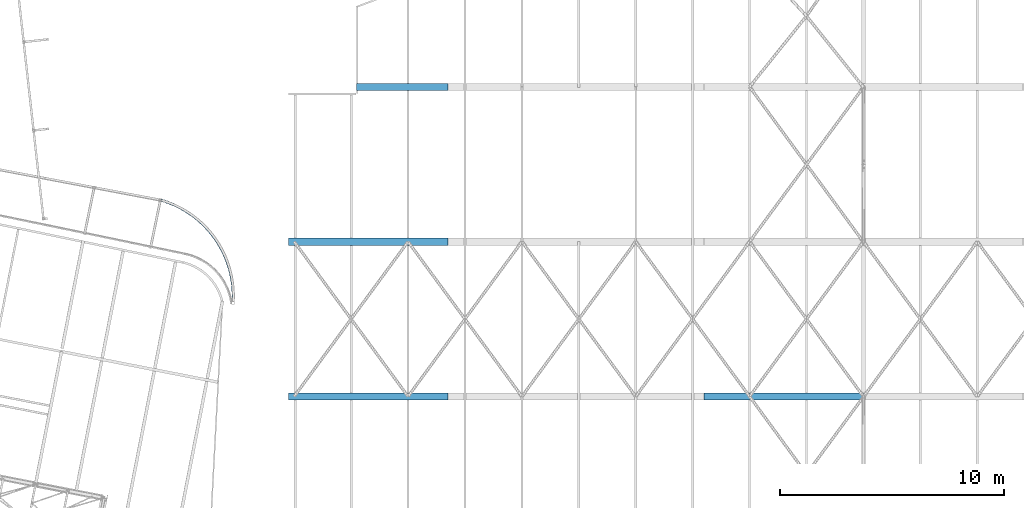
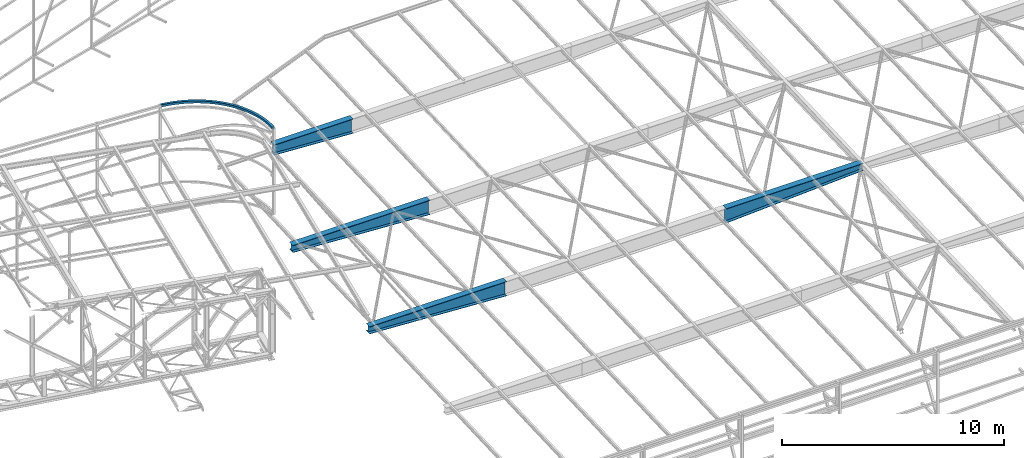
# One storey, part 214 of 215: 5 beams, 5 elements without a shape of their own.
"""IFC2X3 building model written with IfcOpenShell, lengths in millimetres."""

from ifc_helpers import new_model, si_unit, frame, origin_with_axes, place, context, subcontext, project, spatial, faceted_brep, material, type_object, element, aggregate, save


model = new_model("IFC2X3")

# Units and contexts
model_context = context("Model", 3, precision=1e-05, world=origin_with_axes())
body_context = subcontext(model_context, "Body", "Model", "MODEL_VIEW")
ifc_project = project(units=[si_unit("LENGTHUNIT", "METRE", prefix="MILLI"), si_unit("AREAUNIT", "SQUARE_METRE"), si_unit("VOLUMEUNIT", "CUBIC_METRE"), si_unit("MASSUNIT", "GRAM", prefix="KILO"), si_unit("TIMEUNIT", "SECOND"), si_unit("PLANEANGLEUNIT", "RADIAN"), si_unit("SOLIDANGLEUNIT", "STERADIAN"), si_unit("THERMODYNAMICTEMPERATUREUNIT", "DEGREE_CELSIUS"), si_unit("LUMINOUSINTENSITYUNIT", "LUMEN")], contexts=[model_context])

# Site, building, storey
site_placement = place(None, origin_with_axes())
site = spatial("IfcSite", under=ifc_project, at=site_placement, CompositionType="ELEMENT")
building_placement = place(site_placement, origin_with_axes())
building = spatial("IfcBuilding", under=site, at=building_placement, Name="Undefined", CompositionType="ELEMENT")
storey_placement = place(building_placement, origin_with_axes())
storey = spatial("IfcBuildingStorey", under=building, at=storey_placement, Name="Undefined", CompositionType="ELEMENT", Elevation=0.0)

# Assembly, beam
assembly_1_placement = place(storey_placement, origin_with_axes())
assembly_1 = element("IfcElementAssembly", 1, at=assembly_1_placement, inside=storey, Name="Steel Assembly", AssemblyPlace="NOTDEFINED", PredefinedType="RIGID_FRAME")
ifc_material_1 = material(Name="STEEL/S275JR")
beam_type_1 = type_object("IfcBeamType", PredefinedType="NOTDEFINED")
beam_1_placement = place(assembly_1_placement, frame((98183.0956430818, 57531.7367585311, 12221.3440836615), z_axis=(-0.604381100777057, -0.79669535270611, 0.0), x_axis=(0.793723850131004, -0.602126889099379, 0.0862882330142416)))
beam_1 = element("IfcBeam", 2, at=beam_1_placement, type_object=beam_type_1, material=ifc_material_1, Name="LISSE", context=body_context, shape_type="Brep", body=[
    faceted_brep([(-20.4697298194369, -60.3737340840835, -56.0000213738094), (-22.6046588798417, 59.6072730711057, -56.0000213716412), (151.538093515752, 62.5188902682512, -118.950891494111), (153.445107488122, -57.4659275622635, -118.868502462501), (22.6046588798417, -59.6072730711039, 56.0000213716557), (191.921072777841, -56.7763508783919, -5.20617546566064), (20.4697298194733, 60.3737340840853, 56.0000213737949), (190.014058805551, 63.2084669521282, -5.28856449732848), (19.1050811648311, 56.3488184784765, 52.266686615505), (21.0976816211914, -55.6334548663635, 52.266686613526), (-19.1050811648165, -56.3488184784746, -52.2666866155341), (-21.0976816211696, 55.633454866369, -52.2666866135696), (152.884192824531, 58.542382230029, -115.159400959878), (188.795093761619, 59.185987134977, -9.07456242950866), (190.574973469134, -52.7998428401697, -8.9976659999229), (154.66407253201, -53.4434477451232, -115.082504530321), (363.596040468881, -54.2669095552028, -59.4617635604081), (361.920116409747, 65.7212862085398, -59.6171854827408), (329.782553978919, -54.888332930921, -174.597604912036), (328.106629919777, 65.0998628328234, -174.753026834296), (330.853806059939, -50.8680122929381, -170.764924264367), (329.289610271429, 61.1209704198936, -170.909984725193), (362.413060117236, -50.288017142273, -63.3048056695552), (360.848864328706, 61.7009655705533, -63.449866130366), (537.3437547754, -52.083126858799, -106.676417359064), (535.901710732374, 67.9080084724374, -106.89539444253), (508.249040307725, -52.6452414099986, -223.09455003895), (506.80699626467, 67.3458939212378, -223.313527122402), (509.170795988561, -48.6267997472551, -219.22124485235), (507.824888215044, 63.3649265619024, -219.425623463583), (536.325862825019, -48.1021594994691, -110.56432101781), (534.979955051553, 63.8895668096866, -110.768699629058), (712.874957778826, -50.2286383848459, -146.771533165665), (711.669194487724, 69.7649932543027, -147.044481873294), (688.547452670282, -50.7403873334351, -264.27859936867), (687.341689379187, 69.2532443057189, -264.551548076284), (689.318177397523, -46.723541313846, -260.370795452109), (688.192798325872, 65.2705148827008, -260.625547579257), (712.023848832141, -46.2459089618278, -150.697533662678), (710.898469760483, 65.7481472347117, -150.952285789783), (889.897422380593, -48.706531514832, -179.680360002909), (888.929947213393, 71.2891490167676, -179.997606944758), (870.377627443166, -49.1769419321499, -298.081189050296), (869.410152275959, 70.8187385994497, -298.398435992145), (870.996038102145, -45.1614055671907, -294.145069646736), (870.093061279433, 66.8345629289761, -294.441166792501), (889.214513377097, -44.7223558443602, -183.637629202552), (888.311536554371, 67.2736126518084, -183.933726348274), (1068.11643880646, -47.5193402761379, -205.348110739942), (1067.38886242929, 72.4779383214154, -205.699908777839), (1053.43685090085, -47.957508054571, -324.446044002558), (1052.70927452369, 72.0397705429841, -324.797842040454), (1053.9019179518, -43.9429931753675, -320.48783949505), (1053.22284666645, 68.0544668490111, -320.816184330397), (1067.60286666371, -43.5340365821667, -209.32976844997), (1066.92379537834, 68.4634234422174, -209.658113285303), (1247.23530524402, -46.6690411233394, -223.732053302956), (1246.74883893575, 73.3293820531871, -224.108597777333), (1237.42036317838, -47.0841158333242, -343.3292716016), (1236.93389687009, 72.9143073431987, -343.705816076035), (1237.73131237027, -43.0703325704417, -339.355249140819), (1237.27727714922, 68.9281957276471, -339.706690650244), (1246.89192496488, -42.6829295077914, -227.731178728733), (1246.43788974384, 69.315598790301, -228.082620238172), (1426.95582179633, -46.1570496478162, -234.801581816195), (1426.71127543203, 73.8420627151827, -235.193026869383), (1422.02186564018, -46.5582193054815, -354.69943475422), (1421.77731927586, 73.4408930575191, -355.090879807394), (1422.1781792999, -42.5448765714591, -350.71588782467), (1421.94993602653, 69.4542949673378, -351.081236541009), (1426.78320504563, -42.1704515576366, -238.811225082536), (1426.55496177227, 69.8287199811602, -239.176573798832), (1606.97878693006, -45.9842182209959, -238.538267554963), (1606.97656763264, 74.0151267886213, -238.934742522513), (1606.93403081097, -46.3806939918286, -358.537604234312), (1606.93181151354, 73.6186510177886, -358.934079201877), (1606.93544870504, -42.3674999658069, -354.550842177283), (1606.93337736074, 69.6318887098332, -354.9208854803), (1606.97722108284, -41.9974559130351, -242.551461276526), (1606.97514973858, 70.0019327626032, -242.921504579572), (1787.00449559056, -46.1508345753482, -234.935889626329), (1787.24460705304, 73.8482861537013, -235.327515469879), (1791.8490140194, -46.5518354392771, -354.837390197325), (1792.08912548187, 73.4472852897707, -355.229016040932), (1791.69553378718, -42.5384980528488, -350.853727706432), (1791.91963781881, 69.4606812942657, -351.21924516045), (1787.17398325361, -42.1642305798396, -238.945660506826), (1787.39808728528, 69.8349487672676, -239.311177960801), (1966.73323815588, -46.6566213253518, -224.000445325553), (1967.21528063525, 73.341818569339, -224.377351079689), (1976.45896590244, -47.0713587288901, -343.604952817535), (1976.94100838181, 72.9270811658098, -343.981858571715), (1976.1508430602, -43.057586152283, -339.630699426285), (1976.60074937428, 68.9409577494334, -339.982478130187), (1967.07349716342, -42.6704979089864, -227.999825767081), (1967.5234034775, 69.3280459927355, -228.351604470954), (2145.86579939777, -47.5007364293142, -205.750140151649), (2146.58897038048, 72.4965672107028, -206.102479357185), (2160.45654491811, -47.938398950133, -324.858992032794), (2161.17971590083, 72.058904689884, -325.211331238359), (2159.99429243353, -43.9239000781054, -320.900441610283), (2160.66925201739, 68.0735833192448, -321.229291535448), (2146.3762632812, -43.5154150586732, -209.732179854531), (2147.05122286507, 68.4820683386752, -210.061029779696), (2324.10395662005, -48.6817745911612, -180.215357498848), (2325.06705215801, 71.3139392654994, -180.533324595381), (2343.5354290124, -49.1515126408613, -298.630716412445), (2344.49852455036, 70.8442012158011, -298.948683508948), (2342.91981645059, -45.1359975773157, -294.694136685241), (2343.81870561936, 66.8600020222384, -294.990905975312), (2324.78377555106, -44.6975753975948, -184.173135032514), (2325.68266471983, 67.2984242019575, -184.469904322599), (2501.15097614435, -50.1977696000558, -147.438608073542), (2502.35239285932, 69.7959035912772, -147.712454723864), (2525.39082558893, -50.7086801903806, -264.963791200964), (2526.59224230392, 69.2849930009488, -265.2376378513), (2524.62287783129, -46.6918607309944, -261.055413318361), (2525.7442000986, 65.3022342475833, -261.311003525349), (2501.99901834967, -46.2150108466885, -151.365242399494), (2503.12034061699, 65.7790841318892, -151.620832606495), (2676.71210731702, -52.0461976037404, -107.474459122124), (2678.14984506994, 67.9449874376205, -107.694510441448), (2705.71997893257, -52.6073092017559, -223.914265623185), (2707.15771668548, 67.3838758396014, -224.13431694248), (2704.80097447048, -48.5888993137778, -220.040273783787), (2706.14286303986, 63.4028733914911, -220.24565501514), (2677.72696096262, -48.0651951556247, -111.36312104945), (2679.06884953201, 63.9265775496424, -111.568502280847), (2850.4950732146, -54.2239813102988, -60.3894435861293), (2852.16673843547, 65.7642722387536, -60.5461142490094), (2884.22267424179, -54.8442388076401, -175.550479572805), (2885.8943394626, 65.1440147414123, -175.70715023567), (2883.15414304823, -50.8239551060906, -171.717000728706), (2884.714363921, 61.1650815396843, -171.863226680682), (2851.67504875622, -50.2450481085762, -64.2333671411325), (2853.23526962898, 61.743988537206, -64.3795930931519), (3022.21055723115, -56.7274951112795, -6.26194933766965), (3024.11336690374, 63.2573884835238, -6.34575953573221), (3060.6017374311, -57.4157449325539, -119.952949839091), (3062.50454710364, 62.5691386622493, -120.03676003711), (3059.38545841349, -53.3933071520205, -116.166043495643), (3061.1614141079, 58.5925842031356, -116.244266347145), (3023.5536902269, -52.7509406521622, -10.0544430276641), (3025.32964592134, 59.2349507029849, -10.1326658791659), (3191.57268473686, -59.5525711176597, 54.8179113223159), (3193.70347103213, 60.4285096713102, 54.8163200981944), (3234.56352987099, -60.3175464927917, -57.2142360611033), (3236.69431616623, 59.6635342961781, -57.2158272851811), (3233.2015279097, -56.2926779539885, -53.4798841890879), (3235.19026178525, 55.6896641157164, -53.4813693315955), (3193.07673911785, -55.5787009371998, 51.0834533686866), (3195.06547299345, 56.4036411325087, 51.0819682262227), (3358.29949900685, -62.6945060986218, 122.748451684238), (3360.65471455667, 57.2823453639066, 122.838301063806), (3405.81843724228, -63.5448125236362, 12.5612133669638), (3408.17365279212, 56.4320389388904, 12.6510627464741), (3404.31297981941, -59.5172405940502, 16.2371162901982), (3406.51118099924, 52.4611541043087, 16.3209757110744), (3359.96197079967, -58.7236212640346, 119.078538719681), (3362.16017197952, 53.254773434317, 119.162398140557), (3522.11343062684, -66.1480693115409, 197.416579919678), (3524.68915442981, 53.8241333449641, 197.606939300735), (3574.0813516904, -67.0921702219857, 89.257235182944), (3576.65707549333, 52.8800324345102, 89.4475945640152), (3572.43494511506, -63.0616267697587, 92.8688919868728), (3574.83895399777, 48.9124290429827, 93.0465607425431), (3523.93155212241, -62.1804659200061, 193.817613741121), (3526.33556100511, 49.7935898927317, 193.995282496835), (3682.74175959547, -69.9075112102564, 278.697987358057), (3685.53370354446, 50.0596309000721, 278.997758807978), (3739.07214647753, -70.9537138911637, 172.746144647477), (3741.86409042651, 49.0134282191666, 173.04591609737), (3737.28753171309, -66.9199357314556, 176.287865119506), (3739.89334606549, 45.0493969048493, 176.567651806079), (3684.71250395651, -65.9434798959446, 275.176251649391), (3687.31831830889, 46.0258527403657, 275.456038335979), (3839.91706935252, -73.9665730169581, 366.457355438091), (3842.92058537382, 45.995105231912, 366.875258873217), (3900.516142342, -75.123014772711, 262.888948115185), (3903.51965836329, 44.8386634761591, 263.306851550355), (3898.59629044305, -71.0857441058943, 266.355158473772), (3901.39957206293, 40.8784889263861, 266.745201679907), (3842.03715565288, -70.0063984671797, 363.019005308524), (3844.84043727275, 41.9578345650953, 363.409048514659), (3993.37769197823, -78.3184971419068, 460.548580988034), (3996.58777976962, 41.6373230265344, 461.09313965679), (4058.14456478848, -79.5931317491668, 359.535574433699), (4061.35465257987, 40.3626884192763, 360.080133102441), (4056.09267195452, -75.5521165899754, 362.920826607835), (4059.08875389313, 36.4066489005691, 363.429081365306), (3995.64359066496, -74.3624576232032, 457.199632725184), (3998.63967260355, 37.5963078673522, 457.707887482713), (4142.86814382229, -82.9560384336055, 560.815019460526), (4146.27945917757, 36.9935391880736, 561.494545753623), (4211.69499154824, -84.3566228997188, 462.525124784413), (4215.10630690352, 35.5929547219639, 463.204651077569), (4209.51447380253, -80.3116174967872, 465.824105483422), (4212.69836813415, 31.6413216167784, 466.45833002367), (4145.27608259169, -79.0044053284255, 557.561340514396), (4148.45997692328, 32.9485337851456, 558.195565054659), (4288.13955083698, -87.8714762406162, 667.089745716847), (4291.74641454317, 32.0714847606505, 667.912327328973), (4360.91178946356, -89.4055578896096, 571.686140549398), (4364.51865316974, 30.5374031116553, 572.508722161481), (4358.60627696619, -85.3563231346088, 574.893680108755), (4361.97268309197, 26.5904404665816, 575.661422946665), (4290.68552091473, -83.9245135955389, 663.937044931692), (4294.05192704049, 28.0222500056461, 664.704787769631), (4428.95006290639, -93.0566272650103, 779.195831926831), (4432.74647019859, 26.8793540576498, 780.169318391694), (4505.54654007002, -94.7315311727307, 686.836888758276), (4509.34294736222, 25.2044501499258, 687.810375223125), (4503.11987107431, -90.677834998387, 689.947969746048), (4506.66318454701, 21.2624142360946, 690.856557113264), (4431.62982572157, -89.1145913511791, 776.149650036721), (4435.17313919428, 22.8256578833061, 777.058237403922), (4565.06525648257, -98.5028591860791, 896.946642120573), (4569.04488704072, 21.425791019652, 898.078631743265), (4645.35845316737, -100.32567598527, 807.785664640222), (4649.3380837255, 19.6029742204664, 808.917654262899), (4642.81466762983, -96.2672937517673, 810.795430210288), (4646.52898948406, 15.6661131069177, 811.851953858131), (4567.87435072402, -94.5659980725304, 894.012342525326), (4571.58867257828, 17.3674087861546, 895.068866173155), (4696.25852485747, -104.201105031552, 1020.14614290334), (4700.41475332851, 15.7198748239043, 1021.44397011037), (4780.11476769089, -106.178679107235, 934.331110776999), (4784.27099616189, 13.7423007482212, 935.628937984031), (4777.4581005455, -102.115393976199, 937.23487275478), (4781.33724711843, 9.81085388889733, 938.44617814802), (4699.19227390094, -100.269658172221, 1017.32890273935), (4703.07142047393, 11.6565896928623, 1018.5402081326), (4822.31145542111, -110.141878272403, 1148.58922981484), (4826.63736244906, 9.77110476912458, 1150.05995294373), (4909.59113921562, -112.280796367282, 1066.26255232614), (4913.91704624351, 7.63218667425099, 1067.733275455), (4906.82601332339, -108.212399662736, 1069.0557990134), (4910.86352654944, 3.70638450936167, 1070.42847393366), (4825.36497511521, -106.216076107517, 1145.89403133618), (4829.40248834128, 5.70270806457847, 1147.26670625644), (4943.01419327862, -116.315288616221, 1282.06206879044), (4947.5025770239, 3.58938446097272, 1283.71245833878), (5033.5720134484, -118.62186886493, 1203.36034775543), (5038.06039719367, 1.28280421226191, 1205.01073730379), (5030.70303223422, -114.548160420734, 1206.03875144155), (5034.89219039652, -2.63713221535181, 1207.57911502001), (4946.18240007579, -112.395352188605, 1279.49369107418), (4950.37155823808, -0.484323983220747, 1281.03405465267), (5058.16579061972, -122.711058472678, 1420.34245215528), (5062.8091787491, -2.81499467568756, 1422.17897950931), (5151.8509850862, -125.19133988328, 1345.3962545058), (5156.49437321553, -5.29527608628632, 1347.23278185987), (5148.88292487495, -121.112128376355, 1347.95567867257), (5153.21675379569, -9.20913549916622, 1349.66977086966), (5061.44341003958, -118.797199059794, 1417.90546314545), (5065.77723896032, -6.89420618260374, 1419.61955534255), (5167.57454125997, -129.318540063852, 1563.20016855937), (5172.36520338635, -9.43137053005557, 1565.22899522023), (5264.23114144279, -131.978272463995, 1492.13380897295), (5269.02180356914, -12.0911029301969, 1494.16263563378), (5261.16894350755, -127.893375732865, 1494.57031518123), (5265.64022815886, -15.9986841679856, 1496.4638867313), (5170.9561166703, -125.410958826064, 1560.89891746183), (5175.42740132162, -13.5162672611878, 1562.79248901196), (5271.05829979611, -136.126733150817, 1710.39738623692), (5275.98826034838, -16.2487280558998, 1712.6243535626), (5370.52539027205, -138.971367615317, 1643.32872017594), (5375.45535082433, -19.0933625203943, 1645.5556875016), (5274.53820149704, -132.225620796467, 1708.23599627907), (5279.13949801253, -20.3394827078773, 1710.31449911636), (5371.97544912338, -22.9944748747439, 1647.71707745944), (5367.37415260793, -134.880612963338, 1645.63857462213)], [[[0, 1, 2, 3]], [[4, 0, 3, 5]], [[6, 4, 5, 7]], [[1, 6, 7, 2]], [[0, 4, 6, 1], [8, 9, 10, 11]], [[8, 11, 12, 13]], [[9, 8, 13, 14]], [[10, 9, 14, 15]], [[11, 10, 15, 12]], [[5, 16, 17, 7]], [[3, 18, 16, 5]], [[2, 19, 18, 3]], [[7, 17, 19, 2]], [[15, 20, 21, 12]], [[14, 22, 20, 15]], [[13, 23, 22, 14]], [[12, 21, 23, 13]], [[16, 24, 25, 17]], [[18, 26, 24, 16]], [[19, 27, 26, 18]], [[17, 25, 27, 19]], [[20, 28, 29, 21]], [[22, 30, 28, 20]], [[23, 31, 30, 22]], [[21, 29, 31, 23]], [[24, 32, 33, 25]], [[26, 34, 32, 24]], [[27, 35, 34, 26]], [[25, 33, 35, 27]], [[28, 36, 37, 29]], [[30, 38, 36, 28]], [[31, 39, 38, 30]], [[29, 37, 39, 31]], [[32, 40, 41, 33]], [[34, 42, 40, 32]], [[35, 43, 42, 34]], [[33, 41, 43, 35]], [[36, 44, 45, 37]], [[38, 46, 44, 36]], [[39, 47, 46, 38]], [[37, 45, 47, 39]], [[40, 48, 49, 41]], [[42, 50, 48, 40]], [[43, 51, 50, 42]], [[41, 49, 51, 43]], [[44, 52, 53, 45]], [[46, 54, 52, 44]], [[47, 55, 54, 46]], [[45, 53, 55, 47]], [[48, 56, 57, 49]], [[50, 58, 56, 48]], [[51, 59, 58, 50]], [[49, 57, 59, 51]], [[52, 60, 61, 53]], [[54, 62, 60, 52]], [[55, 63, 62, 54]], [[53, 61, 63, 55]], [[56, 64, 65, 57]], [[58, 66, 64, 56]], [[59, 67, 66, 58]], [[57, 65, 67, 59]], [[60, 68, 69, 61]], [[62, 70, 68, 60]], [[63, 71, 70, 62]], [[61, 69, 71, 63]], [[64, 72, 73, 65]], [[66, 74, 72, 64]], [[67, 75, 74, 66]], [[65, 73, 75, 67]], [[68, 76, 77, 69]], [[70, 78, 76, 68]], [[71, 79, 78, 70]], [[69, 77, 79, 71]], [[72, 80, 81, 73]], [[74, 82, 80, 72]], [[75, 83, 82, 74]], [[73, 81, 83, 75]], [[76, 84, 85, 77]], [[78, 86, 84, 76]], [[79, 87, 86, 78]], [[77, 85, 87, 79]], [[80, 88, 89, 81]], [[82, 90, 88, 80]], [[83, 91, 90, 82]], [[81, 89, 91, 83]], [[84, 92, 93, 85]], [[86, 94, 92, 84]], [[87, 95, 94, 86]], [[85, 93, 95, 87]], [[88, 96, 97, 89]], [[90, 98, 96, 88]], [[91, 99, 98, 90]], [[89, 97, 99, 91]], [[92, 100, 101, 93]], [[94, 102, 100, 92]], [[95, 103, 102, 94]], [[93, 101, 103, 95]], [[96, 104, 105, 97]], [[98, 106, 104, 96]], [[99, 107, 106, 98]], [[97, 105, 107, 99]], [[100, 108, 109, 101]], [[102, 110, 108, 100]], [[103, 111, 110, 102]], [[101, 109, 111, 103]], [[104, 112, 113, 105]], [[106, 114, 112, 104]], [[107, 115, 114, 106]], [[105, 113, 115, 107]], [[108, 116, 117, 109]], [[110, 118, 116, 108]], [[111, 119, 118, 110]], [[109, 117, 119, 111]], [[112, 120, 121, 113]], [[114, 122, 120, 112]], [[115, 123, 122, 114]], [[113, 121, 123, 115]], [[116, 124, 125, 117]], [[118, 126, 124, 116]], [[119, 127, 126, 118]], [[117, 125, 127, 119]], [[120, 128, 129, 121]], [[122, 130, 128, 120]], [[123, 131, 130, 122]], [[121, 129, 131, 123]], [[124, 132, 133, 125]], [[126, 134, 132, 124]], [[127, 135, 134, 126]], [[125, 133, 135, 127]], [[128, 136, 137, 129]], [[130, 138, 136, 128]], [[131, 139, 138, 130]], [[129, 137, 139, 131]], [[132, 140, 141, 133]], [[134, 142, 140, 132]], [[135, 143, 142, 134]], [[133, 141, 143, 135]], [[136, 144, 145, 137]], [[138, 146, 144, 136]], [[139, 147, 146, 138]], [[137, 145, 147, 139]], [[140, 148, 149, 141]], [[142, 150, 148, 140]], [[143, 151, 150, 142]], [[141, 149, 151, 143]], [[144, 152, 153, 145]], [[146, 154, 152, 144]], [[147, 155, 154, 146]], [[145, 153, 155, 147]], [[148, 156, 157, 149]], [[150, 158, 156, 148]], [[151, 159, 158, 150]], [[149, 157, 159, 151]], [[152, 160, 161, 153]], [[154, 162, 160, 152]], [[155, 163, 162, 154]], [[153, 161, 163, 155]], [[156, 164, 165, 157]], [[158, 166, 164, 156]], [[159, 167, 166, 158]], [[157, 165, 167, 159]], [[160, 168, 169, 161]], [[162, 170, 168, 160]], [[163, 171, 170, 162]], [[161, 169, 171, 163]], [[164, 172, 173, 165]], [[166, 174, 172, 164]], [[167, 175, 174, 166]], [[165, 173, 175, 167]], [[168, 176, 177, 169]], [[170, 178, 176, 168]], [[171, 179, 178, 170]], [[169, 177, 179, 171]], [[172, 180, 181, 173]], [[174, 182, 180, 172]], [[175, 183, 182, 174]], [[173, 181, 183, 175]], [[176, 184, 185, 177]], [[178, 186, 184, 176]], [[179, 187, 186, 178]], [[177, 185, 187, 179]], [[180, 188, 189, 181]], [[182, 190, 188, 180]], [[183, 191, 190, 182]], [[181, 189, 191, 183]], [[184, 192, 193, 185]], [[186, 194, 192, 184]], [[187, 195, 194, 186]], [[185, 193, 195, 187]], [[188, 196, 197, 189]], [[190, 198, 196, 188]], [[191, 199, 198, 190]], [[189, 197, 199, 191]], [[192, 200, 201, 193]], [[194, 202, 200, 192]], [[195, 203, 202, 194]], [[193, 201, 203, 195]], [[196, 204, 205, 197]], [[198, 206, 204, 196]], [[199, 207, 206, 198]], [[197, 205, 207, 199]], [[200, 208, 209, 201]], [[202, 210, 208, 200]], [[203, 211, 210, 202]], [[201, 209, 211, 203]], [[204, 212, 213, 205]], [[206, 214, 212, 204]], [[207, 215, 214, 206]], [[205, 213, 215, 207]], [[208, 216, 217, 209]], [[210, 218, 216, 208]], [[211, 219, 218, 210]], [[209, 217, 219, 211]], [[212, 220, 221, 213]], [[214, 222, 220, 212]], [[215, 223, 222, 214]], [[213, 221, 223, 215]], [[216, 224, 225, 217]], [[218, 226, 224, 216]], [[219, 227, 226, 218]], [[217, 225, 227, 219]], [[220, 228, 229, 221]], [[222, 230, 228, 220]], [[223, 231, 230, 222]], [[221, 229, 231, 223]], [[224, 232, 233, 225]], [[226, 234, 232, 224]], [[227, 235, 234, 226]], [[225, 233, 235, 227]], [[228, 236, 237, 229]], [[230, 238, 236, 228]], [[231, 239, 238, 230]], [[229, 237, 239, 231]], [[232, 240, 241, 233]], [[234, 242, 240, 232]], [[235, 243, 242, 234]], [[233, 241, 243, 235]], [[236, 244, 245, 237]], [[238, 246, 244, 236]], [[239, 247, 246, 238]], [[237, 245, 247, 239]], [[240, 248, 249, 241]], [[242, 250, 248, 240]], [[243, 251, 250, 242]], [[241, 249, 251, 243]], [[244, 252, 253, 245]], [[246, 254, 252, 244]], [[247, 255, 254, 246]], [[245, 253, 255, 247]], [[248, 256, 257, 249]], [[250, 258, 256, 248]], [[251, 259, 258, 250]], [[249, 257, 259, 251]], [[252, 260, 261, 253]], [[254, 262, 260, 252]], [[255, 263, 262, 254]], [[253, 261, 263, 255]], [[256, 264, 265, 257]], [[258, 266, 264, 256]], [[259, 267, 266, 258]], [[257, 265, 267, 259]], [[264, 266, 267, 265], [268, 269, 270, 271]], [[260, 271, 270, 261]], [[262, 268, 271, 260]], [[263, 269, 268, 262]], [[261, 270, 269, 263]]]),
])
aggregate(assembly_1, [beam_1])

assembly_2_placement = place(storey_placement, origin_with_axes())
assembly_2 = element("IfcElementAssembly", 3, at=assembly_2_placement, inside=storey, Name="Steel Assembly", AssemblyPlace="NOTDEFINED", PredefinedType="RIGID_FRAME")
ifc_material_2 = material(Name="STEEL/S355JR")
beam_type_2 = type_object("IfcBeamType", PredefinedType="NOTDEFINED")
beam_2_placement = place(assembly_2_placement, frame((110996.242228612, 62582.036399848, 3742.69277721701), z_axis=(0.0, 0.0, -1.0), x_axis=(-0.999999999241877, 3.8939000009165e-05, -1.00000005517436e-09)))
beam_2 = element("IfcBeam", 4, at=beam_2_placement, type_object=beam_type_2, material=ifc_material_2, Name="POUTRE", context=body_context, shape_type="Brep", body=[
    faceted_brep([(-2.91038304567337e-11, 160.000000000022, -285.0), (-2.91038304567337e-11, 160.000000000015, -265.0), (4102.20195693958, 160.000000000015, -265.0), (4102.20195693958, 160.000000000022, -285.0), (-2.91038304567337e-11, 3.00000000000728, -265.0), (4102.20195693958, 3.00000000000728, -265.0), (-2.91038304567337e-11, 3.00000000000728, 494.968589077506), (4102.20195693956, 3.00000000001455, 264.968589077506), (-2.91038304567337e-11, 160.000000000015, 494.968589077506), (4102.20195693958, 160.000000000022, 264.968589077506), (-2.91038304567337e-11, 160.000000000015, 515.0), (4102.20195693958, 160.000000000022, 285.0), (-2.91038304567337e-11, -159.999999999993, 515.0), (4102.20195693958, -159.999999999978, 285.0), (-1.45519152283669e-11, -159.999999999993, 494.968589077506), (4102.20195693956, -159.999999999985, 264.968589077506), (-2.91038304567337e-11, -2.99999999998545, 494.968589077506), (4102.20195693958, -2.99999999997817, 264.968589077506), (-2.91038304567337e-11, -2.99999999998545, -265.0), (4102.20195693958, -2.99999999998545, -265.0), (-1.45519152283669e-11, -159.999999999993, -265.0), (4102.20195693958, -159.999999999985, -265.0), (-1.45519152283669e-11, -159.999999999985, -285.0), (4102.20195693958, -159.999999999985, -285.0)], [[[0, 1, 2, 3]], [[1, 4, 5, 2]], [[4, 6, 7, 5]], [[6, 8, 9, 7]], [[8, 10, 11, 9]], [[10, 12, 13, 11]], [[12, 14, 15, 13]], [[14, 16, 17, 15]], [[16, 18, 19, 17]], [[18, 20, 21, 19]], [[20, 22, 23, 21]], [[22, 0, 3, 23]], [[5, 7, 9, 11, 13, 15, 17, 19, 21, 23, 3, 2]], [[22, 20, 18, 16, 14, 12, 10, 8, 6, 4, 1, 0]]]),
])
aggregate(assembly_2, [beam_2])

assembly_3_placement = place(storey_placement, origin_with_axes())
assembly_3 = element("IfcElementAssembly", 5, at=assembly_3_placement, inside=storey, Name="Steel Assembly", AssemblyPlace="NOTDEFINED", PredefinedType="RIGID_FRAME")
beam_type_3 = type_object("IfcBeamType", PredefinedType="NOTDEFINED")
beam_3_placement = place(assembly_3_placement, frame((110996.242228551, 55675.1990114595, 3551.42083502341), z_axis=(0.0, 0.0, -1.0), x_axis=(-0.999999999241877, 3.8939000009165e-05, -1.00000005517436e-09)))
beam_3 = element("IfcBeam", 6, at=beam_3_placement, type_object=beam_type_3, material=ifc_material_2, Name="POUTRE", context=body_context, shape_type="Brep", body=[
    faceted_brep([(-2.91038304567337e-11, 160.000000000007, -200.0), (-2.91038304567337e-11, 160.000000000015, -180.0), (7122.15708385454, 160.000000000007, -180.0), (7122.15708385454, 160.000000000007, -200.0), (-2.91038304567337e-11, 3.00000000000728, -180.0), (7122.15708385453, 3.00000000000728, -180.0), (-1.45519152283669e-11, 3.00000000000728, 579.968482277901), (7122.15708385454, 3.00000000000728, 179.968482277901), (-2.91038304567337e-11, 160.000000000015, 579.968482277902), (7122.15708385454, 160.000000000007, 179.968482277902), (-4.36557456851006e-11, 160.000000000015, 600.0), (7122.15708385454, 160.000000000015, 200.0), (-2.91038304567337e-11, -159.999999999993, 600.0), (7122.15708385454, -160.0, 200.0), (-1.45519152283669e-11, -160.0, 579.968482277902), (7122.15708385454, -160.0, 179.968482277902), (-1.45519152283669e-11, -2.99999999998545, 579.968482277902), (7122.15708385453, -2.99999999998545, 179.968482277902), (-1.45519152283669e-11, -2.99999999998545, -180.0), (7122.15708385453, -2.99999999998545, -180.0), (-2.91038304567337e-11, -160.0, -180.0), (7122.15708385453, -160.0, -180.0), (-1.45519152283669e-11, -160.0, -200.0), (7122.15708385454, -160.0, -200.0)], [[[0, 1, 2, 3]], [[1, 4, 5, 2]], [[4, 6, 7, 5]], [[6, 8, 9, 7]], [[8, 10, 11, 9]], [[10, 12, 13, 11]], [[12, 14, 15, 13]], [[14, 16, 17, 15]], [[16, 18, 19, 17]], [[18, 20, 21, 19]], [[20, 22, 23, 21]], [[22, 0, 3, 23]], [[5, 7, 9, 11, 13, 15, 17, 19, 21, 23, 3, 2]], [[22, 20, 18, 16, 14, 12, 10, 8, 6, 4, 1, 0]]]),
])
aggregate(assembly_3, [beam_3])

assembly_4_placement = place(storey_placement, origin_with_axes())
assembly_4 = element("IfcElementAssembly", 7, at=assembly_4_placement, inside=storey, Name="Steel Assembly", AssemblyPlace="NOTDEFINED", PredefinedType="RIGID_FRAME")
beam_4_placement = place(assembly_4_placement, frame((110996.242228551, 48768.3616230712, 3275.14890291332), z_axis=(0.0, 0.0, -1.0), x_axis=(-0.999999999241877, 3.8939000009165e-05, -1.00000005517436e-09)))
beam_4 = element("IfcBeam", 8, at=beam_4_placement, type_object=beam_type_3, material=ifc_material_2, Name="POUTRE", context=body_context, shape_type="Brep", body=[
    faceted_brep([(-2.91038304567337e-11, 160.000000000007, -200.0), (-2.91038304567337e-11, 160.000000000015, -180.0), (7122.15708385454, 160.000000000007, -180.0), (7122.15708385454, 160.000000000007, -200.0), (-2.91038304567337e-11, 3.00000000000728, -180.0), (7122.15708385453, 3.00000000000728, -180.0), (-1.45519152283669e-11, 3.00000000000728, 579.968482277901), (7122.15708385454, 3.00000000000728, 179.968482277901), (-2.91038304567337e-11, 160.000000000015, 579.968482277902), (7122.15708385454, 160.000000000007, 179.968482277902), (-4.36557456851006e-11, 160.000000000015, 600.0), (7122.15708385454, 160.000000000015, 200.0), (-2.91038304567337e-11, -159.999999999993, 600.0), (7122.15708385454, -160.0, 200.0), (-1.45519152283669e-11, -160.0, 579.968482277902), (7122.15708385454, -160.0, 179.968482277902), (-1.45519152283669e-11, -2.99999999998545, 579.968482277902), (7122.15708385453, -2.99999999998545, 179.968482277902), (-1.45519152283669e-11, -2.99999999998545, -180.0), (7122.15708385453, -2.99999999998545, -180.0), (-2.91038304567337e-11, -160.0, -180.0), (7122.15708385453, -160.0, -180.0), (-1.45519152283669e-11, -160.0, -200.0), (7122.15708385454, -160.0, -200.0)], [[[0, 1, 2, 3]], [[1, 4, 5, 2]], [[4, 6, 7, 5]], [[6, 8, 9, 7]], [[8, 10, 11, 9]], [[10, 12, 13, 11]], [[12, 14, 15, 13]], [[14, 16, 17, 15]], [[16, 18, 19, 17]], [[18, 20, 21, 19]], [[20, 22, 23, 21]], [[22, 0, 3, 23]], [[5, 7, 9, 11, 13, 15, 17, 19, 21, 23, 3, 2]], [[22, 20, 18, 16, 14, 12, 10, 8, 6, 4, 1, 0]]]),
])
aggregate(assembly_4, [beam_4])

assembly_5_placement = place(storey_placement, origin_with_axes())
assembly_5 = element("IfcElementAssembly", 9, at=assembly_5_placement, inside=storey, Name="Steel Assembly", AssemblyPlace="NOTDEFINED", PredefinedType="RIGID_FRAME")
beam_5_placement = place(assembly_5_placement, frame((122402.845953254, 48768.3616230716, 3275.14889202867), z_axis=(0.0, 0.0, -1.0), x_axis=(0.999999999241877, 3.89390000093188e-05, -9.99999996354785e-10)))
beam_5 = element("IfcBeam", 10, at=beam_5_placement, type_object=beam_type_3, material=ifc_material_2, Name="POUTRE", context=body_context, shape_type="Brep", body=[
    faceted_brep([(-2.91038304567337e-11, 160.000000000007, -200.0), (-2.91038304567337e-11, 160.000000000015, -180.0), (7122.15708385454, 160.000000000007, -180.0), (7122.15708385454, 160.000000000007, -200.0), (-2.91038304567337e-11, 3.00000000000728, -180.0), (7122.15708385453, 3.00000000000728, -180.0), (-1.45519152283669e-11, 3.00000000000728, 579.968482277901), (7122.15708385454, 3.00000000000728, 179.968482277901), (-2.91038304567337e-11, 160.000000000015, 579.968482277902), (7122.15708385454, 160.000000000007, 179.968482277902), (-4.36557456851006e-11, 160.000000000015, 600.0), (7122.15708385454, 160.000000000015, 200.0), (-2.91038304567337e-11, -159.999999999993, 600.0), (7122.15708385454, -160.0, 200.0), (-1.45519152283669e-11, -160.0, 579.968482277902), (7122.15708385454, -160.0, 179.968482277902), (-1.45519152283669e-11, -2.99999999998545, 579.968482277902), (7122.15708385453, -2.99999999998545, 179.968482277902), (-1.45519152283669e-11, -2.99999999998545, -180.0), (7122.15708385453, -2.99999999998545, -180.0), (-2.91038304567337e-11, -160.0, -180.0), (7122.15708385453, -160.0, -180.0), (-1.45519152283669e-11, -160.0, -200.0), (7122.15708385454, -160.0, -200.0)], [[[0, 1, 2, 3]], [[1, 4, 5, 2]], [[4, 6, 7, 5]], [[6, 8, 9, 7]], [[8, 10, 11, 9]], [[10, 12, 13, 11]], [[12, 14, 15, 13]], [[14, 16, 17, 15]], [[16, 18, 19, 17]], [[18, 20, 21, 19]], [[20, 22, 23, 21]], [[22, 0, 3, 23]], [[5, 7, 9, 11, 13, 15, 17, 19, 21, 23, 3, 2]], [[22, 20, 18, 16, 14, 12, 10, 8, 6, 4, 1, 0]]]),
])
aggregate(assembly_5, [beam_5])

save(model, "model.ifc")
